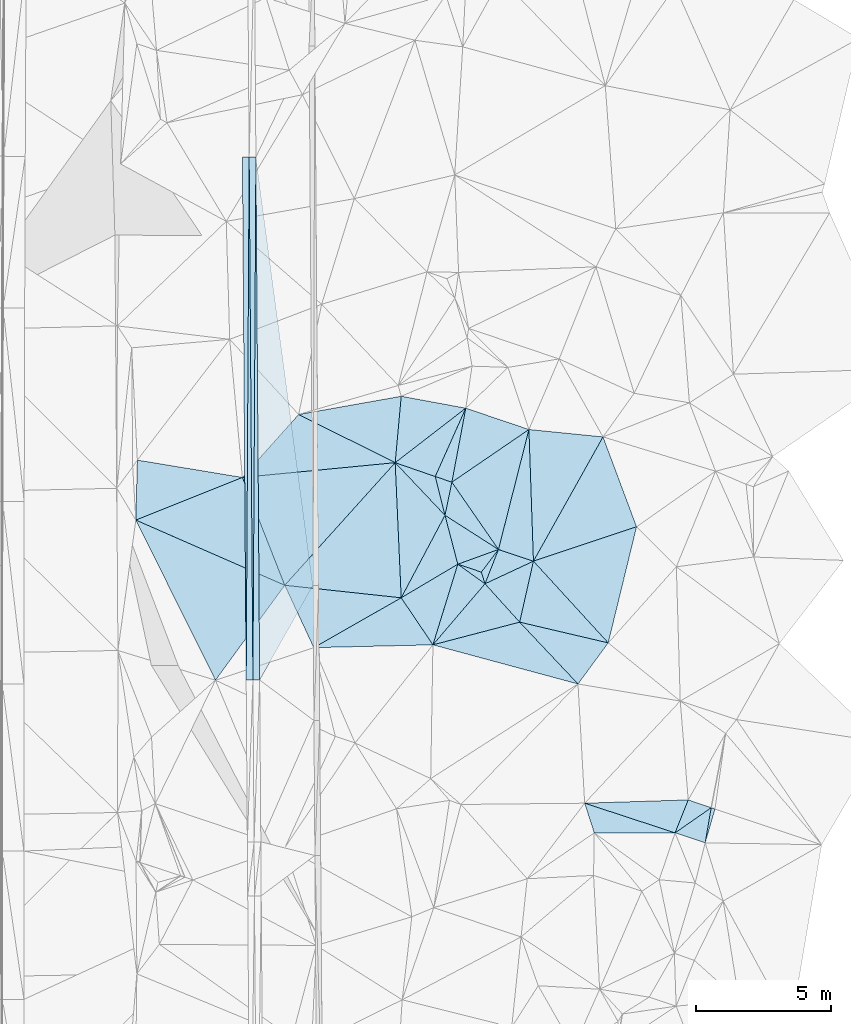
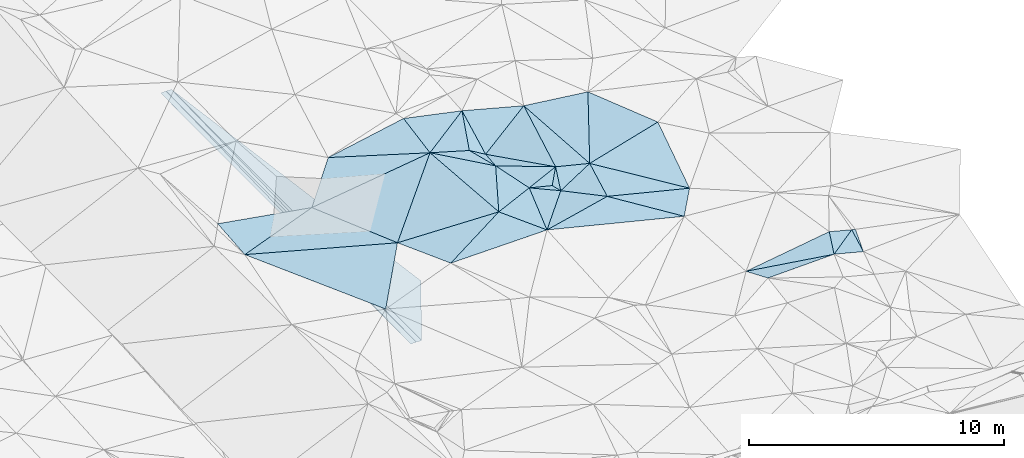
# One storey, part 119 of 275: 45 plates.
"""IFC2X3 building model written with IfcOpenShell, lengths in millimetres."""

from ifc_helpers import new_model, si_unit, frame, origin_with_axes, place, context, subcontext, project, spatial, polyline, outline, extrude, material, type_object, element, save


model = new_model("IFC2X3")

# Units and contexts
model_context = context("Model", 3, precision=1e-05, world=origin_with_axes())
body_context = subcontext(model_context, "Body", "Model", "MODEL_VIEW")
ifc_project = project(units=[si_unit("LENGTHUNIT", "METRE", prefix="MILLI"), si_unit("AREAUNIT", "SQUARE_METRE"), si_unit("VOLUMEUNIT", "CUBIC_METRE"), si_unit("MASSUNIT", "GRAM", prefix="KILO"), si_unit("TIMEUNIT", "SECOND"), si_unit("PLANEANGLEUNIT", "RADIAN"), si_unit("SOLIDANGLEUNIT", "STERADIAN"), si_unit("THERMODYNAMICTEMPERATUREUNIT", "DEGREE_CELSIUS"), si_unit("LUMINOUSINTENSITYUNIT", "LUMEN")], contexts=[model_context])

# Site, building, storey
site_placement = place(None, origin_with_axes())
site = spatial("IfcSite", under=ifc_project, at=site_placement, CompositionType="ELEMENT")
building_placement = place(site_placement, origin_with_axes())
building = spatial("IfcBuilding", under=site, at=building_placement, Name="Undefined", CompositionType="ELEMENT")
storey_placement = place(building_placement, origin_with_axes())
storey = spatial("IfcBuildingStorey", under=building, at=storey_placement, Name="Undefined", CompositionType="ELEMENT", Elevation=0.0)

# Plates
ifc_material = material()
plate_type_1 = type_object("IfcPlateType", PredefinedType="NOTDEFINED")
plate_1_placement = place(storey_placement, frame((-48122.9808228963, 89467.3133438369, 43144.4066906307), z_axis=(-0.0500473094073985, 0.016024451266235, -0.998618287326392), x_axis=(0.00572243998563382, 0.999859466317269, 0.0157575790131864)))
element("IfcPlate", 1, at=plate_1_placement, inside=storey, type_object=plate_type_1, material=ifc_material, Name="00_PR", context=body_context, shape_type="SweptSolid", body=[
    extrude(outline(polyline([(0.0, 0.0), (19378.421875, 1.21683115139604e-07), (3.02767777442932, 250.293533325195), (0.0, 0.0)])), frame((-8.85201319254618e-08, 2.18876761149539e-07, -0.5000001331573), z_axis=(0.0, 0.0, 1.0), x_axis=(1.0, 0.0, 0.0)), (0.0, 0.0, 1.0), 1.0),
])
plate_2_placement = place(storey_placement, frame((-48122.9808228963, 89467.3133438369, 43144.4066906307), z_axis=(-0.0500473094073985, 0.016024451266235, -0.998618287326392), x_axis=(-0.00717867400976242, 0.999839677812784, 0.0164038200029431)))
element("IfcPlate", 2, at=plate_2_placement, inside=storey, type_object=plate_type_1, material=ifc_material, Name="00_PR", context=body_context, shape_type="SweptSolid", body=[
    extrude(outline(polyline([(0.0, 0.0), (19377.009765625, -3.88390617445111e-08), (19376.8046875, 250.311752319336), (0.0, 0.0)])), frame((-8.85201319254618e-08, 2.18876761149539e-07, -0.5000001331573), z_axis=(0.0, 0.0, 1.0), x_axis=(1.0, 0.0, 0.0)), (0.0, 0.0, 1.0), 1.0),
])
for number, where, z_axis, x_axis, name in (
    (3, (-48262.0471143555, 108841.217587926, 43462.2631684603), (0.0198750218653366, 0.016543663038626, -0.999665589444349), (0.0071786740281962, -0.999839677812214, -0.0164038200296701), "00_PR"),
    (4, (-48372.9398667531, 89465.5188689199, 43139.4061675261), (0.0198750218653366, 0.016543663038626, -0.999665589444349), (-0.00717867400976242, 0.999839677812784, 0.0164038200029431), "00_PR"),
):
    element("IfcPlate", number, at=place(storey_placement, frame(where, z_axis=z_axis, x_axis=x_axis)), inside=storey, type_object=plate_type_1, material=ifc_material, Name=name, context=body_context, shape_type="SweptSolid", body=[
        extrude(outline(polyline([(0.0, 0.0), (19377.009765625, -3.88390617445111e-08), (19377.091796875, 250.050430297852), (0.0, 0.0)])), frame((-8.85201319254618e-08, 2.18876761149539e-07, -0.5000001331573), z_axis=(0.0, 0.0, 1.0), x_axis=(1.0, 0.0, 0.0)), (0.0, 0.0, 1.0), 1.0),
    ])
plate_type_2 = type_object("IfcPlateType", PredefinedType="NOTDEFINED")
plate_3_placement = place(storey_placement, frame((-48012.0638828825, 108843.011848514, 43449.763068454), z_axis=(0.000146586582511709, 0.0164052945620828, -0.99986541335457), x_axis=(0.131963060984313, -0.991121552727406, -0.0162424830264985)))
element("IfcPlate", 5, at=plate_3_placement, inside=storey, type_object=plate_type_2, material=ifc_material, Name="00_PR", context=body_context, shape_type="SweptSolid", body=[
    extrude(outline(polyline([(0.0, 0.0), (16020.025390625, -6.14600139670074e-08), (19225.412109375, 2419.09912109375), (0.0, 0.0)])), frame((-8.85201319254618e-08, 2.18876761149539e-07, -0.5000001331573), z_axis=(0.0, 0.0, 1.0), x_axis=(1.0, 0.0, 0.0)), (0.0, 0.0, 1.0), 1.0),
])
plate_type_3 = type_object("IfcPlateType", PredefinedType="NOTDEFINED")
plate_4_placement = place(storey_placement, frame((-37727.8266010062, 93870.9310291532, 45389.5018838814), z_axis=(-0.080682914719458, 0.0314461321567878, -0.996243648935716), x_axis=(0.673052587282011, -0.735499239085719, -0.0777244109486793)))
element("IfcPlate", 6, at=plate_4_placement, inside=storey, type_object=plate_type_3, material=ifc_material, Name="00", context=body_context, shape_type="SweptSolid", body=[
    extrude(outline(polyline([(0.0, 0.0), (4117.11083984375, -2.31375452131033e-09), (1320.63488769531, 1902.84619140625), (0.0, 0.0)])), frame((-8.85201319254618e-08, 2.18876761149539e-07, -0.5000001331573), z_axis=(0.0, 0.0, 1.0), x_axis=(1.0, 0.0, 0.0)), (0.0, 0.0, 1.0), 1.0),
])
plate_type_4 = type_object("IfcPlateType", PredefinedType="NOTDEFINED")
plate_5_placement = place(storey_placement, frame((-40749.8617339183, 96798.9210207401, 45109.5131965546), z_axis=(-0.112277293693529, -0.198650048645683, -0.973617978210101), x_axis=(0.566023629175378, -0.818098694053421, 0.101645354066094)))
element("IfcPlate", 7, at=plate_5_placement, inside=storey, type_object=plate_type_4, material=ifc_material, Name="00", context=body_context, shape_type="SweptSolid", body=[
    extrude(outline(polyline([(0.0, 0.0), (3049.81958007813, -2.15623003896326e-08), (888.675476074219, 928.415771484375), (0.0, 0.0)])), frame((-8.85201319254618e-08, 2.18876761149539e-07, -0.5000001331573), z_axis=(0.0, 0.0, 1.0), x_axis=(1.0, 0.0, 0.0)), (0.0, 0.0, 1.0), 1.0),
])
plate_type_5 = type_object("IfcPlateType", PredefinedType="NOTDEFINED")
plate_6_placement = place(storey_placement, frame((-31363.7656839935, 83432.8939969988, 45269.5046348812), z_axis=(0.00948778259357659, 0.135423983560753, -0.990742310925497), x_axis=(-0.948376948098329, 0.315315594849185, 0.0340182298275974)))
element("IfcPlate", 8, at=plate_6_placement, inside=storey, type_object=plate_type_5, material=ifc_material, Name="00", context=body_context, shape_type="SweptSolid", body=[
    extrude(outline(polyline([(0.0, 0.0), (1175.84008789063, -1.03318598121405e-09), (205.044876098633, 1316.53198242188), (0.0, 0.0)])), frame((-8.85201319254618e-08, 2.18876761149539e-07, -0.5000001331573), z_axis=(0.0, 0.0, 1.0), x_axis=(1.0, 0.0, 0.0)), (0.0, 0.0, 1.0), 1.0),
])
plate_type_6 = type_object("IfcPlateType", PredefinedType="NOTDEFINED")
plate_7_placement = place(storey_placement, frame((-37727.7371115191, 93870.9108578284, 45389.5024445987), z_axis=(0.0984627287842931, -0.00901694546911202, -0.995099887315217), x_axis=(-0.220219844346182, -0.975364271991149, -0.0129521071381955)))
element("IfcPlate", 9, at=plate_7_placement, inside=storey, type_object=plate_type_6, material=ifc_material, Name="00", context=body_context, shape_type="SweptSolid", body=[
    extrude(outline(polyline([(0.0, 0.0), (2316.22534179688, -1.4479155652225e-08), (1214.0009765625, 1573.88098144531), (0.0, 0.0)])), frame((-8.85201319254618e-08, 2.18876761149539e-07, -0.5000001331573), z_axis=(0.0, 0.0, 1.0), x_axis=(1.0, 0.0, 0.0)), (0.0, 0.0, 1.0), 1.0),
])
plate_type_7 = type_object("IfcPlateType", PredefinedType="NOTDEFINED")
plate_8_placement = place(storey_placement, frame((-40749.9827795415, 96799.0940326438, 45109.5382957432), z_axis=(-0.354371805912794, 0.147369052884015, -0.923419181859557), x_axis=(-0.875177603417326, 0.295558053959943, 0.383026890983018)))
element("IfcPlate", 10, at=plate_8_placement, inside=storey, type_object=plate_type_7, material=ifc_material, Name="00", context=body_context, shape_type="SweptSolid", body=[
    extrude(outline(polyline([(0.0, 0.0), (704.911315917969, 1.97906047105789e-09), (451.688018798828, 2764.05102539063), (0.0, 0.0)])), frame((-8.85201319254618e-08, 2.18876761149539e-07, -0.5000001331573), z_axis=(0.0, 0.0, 1.0), x_axis=(1.0, 0.0, 0.0)), (0.0, 0.0, 1.0), 1.0),
])
plate_type_8 = type_object("IfcPlateType", PredefinedType="NOTDEFINED")
plate_9_placement = place(storey_placement, frame((-35149.9221291523, 98476.5256779097, 45119.500676482), z_axis=(-0.0177744832084789, -0.0485965442518217, -0.998660324451438), x_axis=(0.349358261161334, -0.936163116077967, 0.039337329008469)))
element("IfcPlate", 11, at=plate_9_placement, inside=storey, type_object=plate_type_8, material=ifc_material, Name="00", context=body_context, shape_type="SweptSolid", body=[
    extrude(outline(polyline([(0.0, 0.0), (3558.96044921875, -1.43561464938102e-08), (3421.64526367188, 4027.72192382813), (0.0, 0.0)])), frame((-8.85201319254618e-08, 2.18876761149539e-07, -0.5000001331573), z_axis=(0.0, 0.0, 1.0), x_axis=(1.0, 0.0, 0.0)), (0.0, 0.0, 1.0), 1.0),
])
plate_type_9 = type_object("IfcPlateType", PredefinedType="NOTDEFINED")
plate_10_placement = place(storey_placement, frame((-39023.4903981059, 94303.936381236, 45419.5029865571), z_axis=(0.0904023441567215, -0.0609577828379549, -0.994038009777519), x_axis=(-0.56602362917922, 0.818098694050903, -0.101645354064962)))
element("IfcPlate", 12, at=plate_10_placement, inside=storey, type_object=plate_type_9, material=ifc_material, Name="00", context=body_context, shape_type="SweptSolid", body=[
    extrude(outline(polyline([(0.0, 0.0), (3049.81958007813, -2.15623003896326e-08), (3015.71923828125, 3460.5400390625), (0.0, 0.0)])), frame((-8.85201319254618e-08, 2.18876761149539e-07, -0.5000001331573), z_axis=(0.0, 0.0, 1.0), x_axis=(1.0, 0.0, 0.0)), (0.0, 0.0, 1.0), 1.0),
])
plate_type_10 = type_object("IfcPlateType", PredefinedType="NOTDEFINED")
plate_11_placement = place(storey_placement, frame((-37727.8114112109, 93870.9001221443, 45389.5008696403), z_axis=(-0.0503026542644828, -0.0303670749304011, -0.998272249305829), x_axis=(-0.034212409149329, 0.999003407415456, -0.0286653629404365)))
element("IfcPlate", 13, at=plate_11_placement, inside=storey, type_object=plate_type_10, material=ifc_material, Name="00", context=body_context, shape_type="SweptSolid", body=[
    extrude(outline(polyline([(0.0, 0.0), (4883.94287109375, 3.31565388478339e-08), (4520.58935546875, 2737.60375976563), (0.0, 0.0)])), frame((-8.85201319254618e-08, 2.18876761149539e-07, -0.5000001331573), z_axis=(0.0, 0.0, 1.0), x_axis=(1.0, 0.0, 0.0)), (0.0, 0.0, 1.0), 1.0),
])
plate_type_11 = type_object("IfcPlateType", PredefinedType="NOTDEFINED")
plate_12_placement = place(storey_placement, frame((-41005.2536208272, 95570.8929000039, 45389.5523729539), z_axis=(-0.43053371957384, -0.114641399757529, -0.895264243545753), x_axis=(-0.244173331230418, 0.9697081053724, -0.00675090297006514)))
element("IfcPlate", 14, at=plate_12_placement, inside=storey, type_object=plate_type_11, material=ifc_material, Name="00", context=body_context, shape_type="SweptSolid", body=[
    extrude(outline(polyline([(0.0, 0.0), (1481.283203125, 4.82395989820361e-09), (1130.43872070313, 611.398559570313), (0.0, 0.0)])), frame((-8.85201319254618e-08, 2.18876761149539e-07, -0.5000001331573), z_axis=(0.0, 0.0, 1.0), x_axis=(1.0, 0.0, 0.0)), (0.0, 0.0, 1.0), 1.0),
])
plate_type_12 = type_object("IfcPlateType", PredefinedType="NOTDEFINED")
plate_13_placement = place(storey_placement, frame((-39023.5179513791, 94304.0532799282, 45419.5078465396), z_axis=(0.0352952482510373, 0.172836099479648, -0.984318001546024), x_axis=(-0.596145144930375, -0.786865542160084, -0.159541796207323)))
element("IfcPlate", 15, at=plate_13_placement, inside=storey, type_object=plate_type_12, material=ifc_material, Name="00", context=body_context, shape_type="SweptSolid", body=[
    extrude(outline(polyline([(0.0, 0.0), (1065.55151367188, -3.40514816343784e-09), (1352.72668457031, 874.488647460938), (0.0, 0.0)])), frame((-8.85201319254618e-08, 2.18876761149539e-07, -0.5000001331573), z_axis=(0.0, 0.0, 1.0), x_axis=(1.0, 0.0, 0.0)), (0.0, 0.0, 1.0), 1.0),
])
plate_type_13 = type_object("IfcPlateType", PredefinedType="NOTDEFINED")
plate_14_placement = place(storey_placement, frame((-37894.8942615437, 98749.9761838048, 45249.5005020277), z_axis=(-0.0330886544400398, -0.0297986694269383, -0.999008098189265), x_axis=(0.0342124091444801, -0.99900340741576, 0.0286653629356254)))
element("IfcPlate", 16, at=plate_14_placement, inside=storey, type_object=plate_type_13, material=ifc_material, Name="00", context=body_context, shape_type="SweptSolid", body=[
    extrude(outline(polyline([(0.0, 0.0), (4883.94287109375, 3.31565388478339e-08), (4407.8525390625, 1280.91284179688), (0.0, 0.0)])), frame((-8.85201319254618e-08, 2.18876761149539e-07, -0.5000001331573), z_axis=(0.0, 0.0, 1.0), x_axis=(1.0, 0.0, 0.0)), (0.0, 0.0, 1.0), 1.0),
])
plate_type_14 = type_object("IfcPlateType", PredefinedType="NOTDEFINED")
plate_15_placement = place(storey_placement, frame((-39023.5227174912, 94304.0396596911, 45419.5055016167), z_axis=(0.0257626654507343, 0.145599752683723, -0.989008087473157), x_axis=(0.948205169685298, -0.316899041749468, -0.0219534398294409)))
element("IfcPlate", 17, at=plate_15_placement, inside=storey, type_object=plate_type_14, material=ifc_material, Name="00", context=body_context, shape_type="SweptSolid", body=[
    extrude(outline(polyline([(0.0, 0.0), (1366.52844238281, 1.87719706445932e-09), (-66.2262115478516, 1377.72058105469), (0.0, 0.0)])), frame((-8.85201319254618e-08, 2.18876761149539e-07, -0.5000001331573), z_axis=(0.0, 0.0, 1.0), x_axis=(1.0, 0.0, 0.0)), (0.0, 0.0, 1.0), 1.0),
])
plate_type_15 = type_object("IfcPlateType", PredefinedType="NOTDEFINED")
plate_16_placement = place(storey_placement, frame((-39658.7587649784, 93465.5558152671, 45249.5012122396), z_axis=(0.000376762323837831, 0.0694293524422343, -0.99758679976712), x_axis=(0.300210781110649, -0.951578915828308, -0.0661139460019991)))
element("IfcPlate", 18, at=plate_16_placement, inside=storey, type_object=plate_type_15, material=ifc_material, Name="00", context=body_context, shape_type="SweptSolid", body=[
    extrude(outline(polyline([(0.0, 0.0), (453.762054443359, -2.29556462727487e-09), (-541.252868652344, 744.4765625), (0.0, 0.0)])), frame((-8.85201319254618e-08, 2.18876761149539e-07, -0.5000001331573), z_axis=(0.0, 0.0, 1.0), x_axis=(1.0, 0.0, 0.0)), (0.0, 0.0, 1.0), 1.0),
])
plate_type_16 = type_object("IfcPlateType", PredefinedType="NOTDEFINED")
plate_17_placement = place(storey_placement, frame((-40531.3505668799, 93757.6657438974, 45269.5029408336), z_axis=(0.068568606146781, 0.0836988149836219, -0.994129194129931), x_axis=(-0.252211091121483, 0.9655602828409, 0.0638976190128594)))
element("IfcPlate", 19, at=plate_17_placement, inside=storey, type_object=plate_type_16, material=ifc_material, Name="00", context=body_context, shape_type="SweptSolid", body=[
    extrude(outline(polyline([(0.0, 0.0), (1878.00427246094, 1.86810211744159e-09), (156.815399169922, 1603.12475585938), (0.0, 0.0)])), frame((-8.85201319254618e-08, 2.18876761149539e-07, -0.5000001331573), z_axis=(0.0, 0.0, 1.0), x_axis=(1.0, 0.0, 0.0)), (0.0, 0.0, 1.0), 1.0),
])
plate_type_17 = type_object("IfcPlateType", PredefinedType="NOTDEFINED")
plate_18_placement = place(storey_placement, frame((-34956.7807458992, 90842.812037416, 45069.5015190974), z_axis=(-0.052901474210557, 0.0569460795665654, -0.996974712842983), x_axis=(-0.673052587295684, 0.735499239074036, 0.0777244109408357)))
element("IfcPlate", 20, at=plate_18_placement, inside=storey, type_object=plate_type_17, material=ifc_material, Name="00", context=body_context, shape_type="SweptSolid", body=[
    extrude(outline(polyline([(0.0, 0.0), (4117.11083984375, -2.31375452131033e-09), (2472.04907226563, 3679.01782226563), (0.0, 0.0)])), frame((-8.85201319254618e-08, 2.18876761149539e-07, -0.5000001331573), z_axis=(0.0, 0.0, 1.0), x_axis=(1.0, 0.0, 0.0)), (0.0, 0.0, 1.0), 1.0),
])
plate_type_18 = type_object("IfcPlateType", PredefinedType="NOTDEFINED")
plate_19_placement = place(storey_placement, frame((-39522.4734234203, 93033.7843047484, 45219.5066777543), z_axis=(0.122540852766194, 0.107211064681001, -0.986655728718635), x_axis=(-0.300210781116809, 0.951578915826714, 0.0661139459969808)))
element("IfcPlate", 21, at=plate_19_placement, inside=storey, type_object=plate_type_18, material=ifc_material, Name="00", context=body_context, shape_type="SweptSolid", body=[
    extrude(outline(polyline([(0.0, 0.0), (453.762054443359, -2.29556462727487e-09), (1072.14782714844, 867.755187988281), (0.0, 0.0)])), frame((-8.85201319254618e-08, 2.18876761149539e-07, -0.5000001331573), z_axis=(0.0, 0.0, 1.0), x_axis=(1.0, 0.0, 0.0)), (0.0, 0.0, 1.0), 1.0),
])
plate_type_19 = type_object("IfcPlateType", PredefinedType="NOTDEFINED")
plate_20_placement = place(storey_placement, frame((-39522.5280701252, 93033.6876433415, 45219.5019067768), z_axis=(0.0132467953505022, -0.0861123031991422, -0.996197366815774), x_axis=(0.668591136258281, -0.740052104085696, 0.0728613460978829)))
element("IfcPlate", 22, at=plate_20_placement, inside=storey, type_object=plate_type_19, material=ifc_material, Name="00", context=body_context, shape_type="SweptSolid", body=[
    extrude(outline(polyline([(0.0, 0.0), (1921.45776367188, 8.75661498866975e-09), (397.406585693359, 2952.53588867188), (0.0, 0.0)])), frame((-8.85201319254618e-08, 2.18876761149539e-07, -0.5000001331573), z_axis=(0.0, 0.0, 1.0), x_axis=(1.0, 0.0, 0.0)), (0.0, 0.0, 1.0), 1.0),
])
plate_type_20 = type_object("IfcPlateType", PredefinedType="NOTDEFINED")
plate_21_placement = place(storey_placement, frame((-34956.7898384862, 90842.8195021556, 45069.5025673802), z_axis=(-0.0710871790636121, 0.0718748448805464, -0.994877188222836), x_axis=(-0.592359464910988, -0.805517506131453, -0.0158685741682458)))
element("IfcPlate", 23, at=plate_21_placement, inside=storey, type_object=plate_type_20, material=ifc_material, Name="00", context=body_context, shape_type="SweptSolid", body=[
    extrude(outline(polyline([(0.0, 0.0), (1890.52905273438, -3.39059624820948e-09), (1319.57775878906, 3114.45263671875), (0.0, 0.0)])), frame((-8.85201319254618e-08, 2.18876761149539e-07, -0.5000001331573), z_axis=(0.0, 0.0, 1.0), x_axis=(1.0, 0.0, 0.0)), (0.0, 0.0, 1.0), 1.0),
])
plate_type_21 = type_object("IfcPlateType", PredefinedType="NOTDEFINED")
plate_22_placement = place(storey_placement, frame((-38237.8833428072, 91611.8039661408, 45359.5030677998), z_axis=(-0.0365772784975865, 0.104278532994865, -0.993875289085179), x_axis=(0.682563524106156, -0.723804798867315, -0.101062597910555)))
element("IfcPlate", 24, at=plate_22_placement, inside=storey, type_object=plate_type_21, material=ifc_material, Name="00", context=body_context, shape_type="SweptSolid", body=[
    extrude(outline(polyline([(0.0, 0.0), (3166.3544921875, -1.78770278580487e-08), (-1587.85131835938, 2918.72021484375), (0.0, 0.0)])), frame((-8.85201319254618e-08, 2.18876761149539e-07, -0.5000001331573), z_axis=(0.0, 0.0, 1.0), x_axis=(1.0, 0.0, 0.0)), (0.0, 0.0, 1.0), 1.0),
])
plate_type_22 = type_object("IfcPlateType", PredefinedType="NOTDEFINED")
plate_23_placement = place(storey_placement, frame((-31991.1700905661, 85025.1753849519, 45479.5045187698), z_axis=(0.0107707580183382, 0.133614066467999, -0.99097490988097), x_axis=(0.945584546155765, -0.323661599866354, -0.033362176837685)))
element("IfcPlate", 25, at=plate_23_placement, inside=storey, type_object=plate_type_22, material=ifc_material, Name="00", context=body_context, shape_type="SweptSolid", body=[
    extrude(outline(polyline([(0.0, 0.0), (899.221862792969, -1.73167791217566e-09), (-60.1631278991699, 1324.86999511719), (0.0, 0.0)])), frame((-8.85201319254618e-08, 2.18876761149539e-07, -0.5000001331573), z_axis=(0.0, 0.0, 1.0), x_axis=(1.0, 0.0, 0.0)), (0.0, 0.0, 1.0), 1.0),
])
plate_type_23 = type_object("IfcPlateType", PredefinedType="NOTDEFINED")
plate_24_placement = place(storey_placement, frame((-31140.8635650484, 84734.1298017342, 45449.5046959273), z_axis=(0.0431835440785026, 0.129635546440962, -0.990620919736593), x_axis=(0.948745425085232, -0.316041323848391, 1.70029327735896e-10)))
element("IfcPlate", 26, at=plate_24_placement, inside=storey, type_object=plate_type_23, material=ifc_material, Name="00", context=body_context, shape_type="SweptSolid", body=[
    extrude(outline(polyline([(0.0, 0.0), (148.660690307617, 2.47382558882236e-10), (199.783813476563, 1317.34069824219), (0.0, 0.0)])), frame((-8.85201319254618e-08, 2.18876761149539e-07, -0.5000001331573), z_axis=(0.0, 0.0, 1.0), x_axis=(1.0, 0.0, 0.0)), (0.0, 0.0, 1.0), 1.0),
])
plate_type_24 = type_object("IfcPlateType", PredefinedType="NOTDEFINED")
plate_25_placement = place(storey_placement, frame((-32478.8497038633, 83803.631694375, 45309.5056818039), z_axis=(0.120786747267147, 0.0893625512525177, -0.988648014269115), x_axis=(-0.946531691025131, 0.310496740842927, -0.087575863176026)))
element("IfcPlate", 27, at=plate_25_placement, inside=storey, type_object=plate_type_24, material=ifc_material, Name="00", context=body_context, shape_type="SweptSolid", body=[
    extrude(outline(polyline([(0.0, 0.0), (3539.7880859375, 3.05590219795704e-10), (-97.2657089233398, 1322.66369628906), (0.0, 0.0)])), frame((-8.85201319254618e-08, 2.18876761149539e-07, -0.5000001331573), z_axis=(0.0, 0.0, 1.0), x_axis=(1.0, 0.0, 0.0)), (0.0, 0.0, 1.0), 1.0),
])
plate_type_25 = type_object("IfcPlateType", PredefinedType="NOTDEFINED")
plate_26_placement = place(storey_placement, frame((-35474.1746749848, 83802.2668341385, 45219.5090274375), z_axis=(0.0295815977631143, -0.186783572318515, -0.98195561314436), x_axis=(-0.301823274079135, 0.934860647808372, -0.186917843994259)))
element("IfcPlate", 28, at=plate_26_placement, inside=storey, type_object=plate_type_25, material=ifc_material, Name="00", context=body_context, shape_type="SweptSolid", body=[
    extrude(outline(polyline([(0.0, 0.0), (1176.98767089844, 2.25554686039686e-10), (-919.720764160156, 2852.00170898438), (0.0, 0.0)])), frame((-8.85201319254618e-08, 2.18876761149539e-07, -0.5000001331573), z_axis=(0.0, 0.0, 1.0), x_axis=(1.0, 0.0, 0.0)), (0.0, 0.0, 1.0), 1.0),
])
plate_type_26 = type_object("IfcPlateType", PredefinedType="NOTDEFINED")
plate_27_placement = place(storey_placement, frame((-42851.2121888948, 97520.9840433633, 45479.5016289314), z_axis=(-0.0761850849984336, -0.0261226432295661, -0.996751443607925), x_axis=(0.943118583344109, -0.326329354948163, -0.0635333758753378)))
element("IfcPlate", 29, at=plate_27_placement, inside=storey, type_object=plate_type_26, material=ifc_material, Name="00", context=body_context, shape_type="SweptSolid", body=[
    extrude(outline(polyline([(0.0, 0.0), (1573.97583007813, -7.74161890149117e-09), (2383.20043945313, 1240.70764160156), (0.0, 0.0)])), frame((-8.85201319254618e-08, 2.18876761149539e-07, -0.5000001331573), z_axis=(0.0, 0.0, 1.0), x_axis=(1.0, 0.0, 0.0)), (0.0, 0.0, 1.0), 1.0),
])
plate_type_27 = type_object("IfcPlateType", PredefinedType="NOTDEFINED")
plate_28_placement = place(storey_placement, frame((-41005.0781858345, 95570.9355119672, 45389.5018110205), z_axis=(-0.0796588593439748, -0.0294281003286373, -0.996387702171732), x_axis=(-0.467842638580197, -0.881532067540762, 0.0634387848530271)))
element("IfcPlate", 30, at=plate_28_placement, inside=storey, type_object=plate_type_27, material=ifc_material, Name="00", context=body_context, shape_type="SweptSolid", body=[
    extrude(outline(polyline([(0.0, 0.0), (3467.90991210938, -4.88944351673126e-09), (-849.618347167969, 2548.95043945313), (0.0, 0.0)])), frame((-8.85201319254618e-08, 2.18876761149539e-07, -0.5000001331573), z_axis=(0.0, 0.0, 1.0), x_axis=(1.0, 0.0, 0.0)), (0.0, 0.0, 1.0), 1.0),
])
plate_type_28 = type_object("IfcPlateType", PredefinedType="NOTDEFINED")
plate_29_placement = place(storey_placement, frame((-42627.01287194, 99981.7737473387, 45549.5003892876), z_axis=(0.0296012627651281, 0.0257282418469203, -0.999230615430781), x_axis=(-0.090676226858363, -0.995477736323768, -0.0283178100572396)))
element("IfcPlate", 31, at=plate_29_placement, inside=storey, type_object=plate_type_28, material=ifc_material, Name="00", context=body_context, shape_type="SweptSolid", body=[
    extrude(outline(polyline([(0.0, 0.0), (2471.94262695313, 1.33150024339557e-09), (1020.20977783203, 3726.25439453125), (0.0, 0.0)])), frame((-8.85201319254618e-08, 2.18876761149539e-07, -0.5000001331573), z_axis=(0.0, 0.0, 1.0), x_axis=(1.0, 0.0, 0.0)), (0.0, 0.0, 1.0), 1.0),
])
plate_type_29 = type_object("IfcPlateType", PredefinedType="NOTDEFINED")
plate_30_placement = place(storey_placement, frame((-42627.4468903394, 92513.8646012652, 45609.5009069535), z_axis=(0.0552923960677207, -0.0234458999911983, -0.99819489114636), x_axis=(-0.99261817647025, 0.106788816882269, -0.0574917761924283)))
element("IfcPlate", 32, at=plate_30_placement, inside=storey, type_object=plate_type_29, material=ifc_material, Name="00", context=body_context, shape_type="SweptSolid", body=[
    extrude(outline(polyline([(0.0, 0.0), (4348.4482421875, -1.13795977085829e-08), (764.226684570313, 4955.21533203125), (0.0, 0.0)])), frame((-8.85201319254618e-08, 2.18876761149539e-07, -0.5000001331573), z_axis=(0.0, 0.0, 1.0), x_axis=(1.0, 0.0, 0.0)), (0.0, 0.0, 1.0), 1.0),
])
plate_type_30 = type_object("IfcPlateType", PredefinedType="NOTDEFINED")
plate_31_placement = place(storey_placement, frame((-41452.1621198695, 90770.2525597651, 45389.5070573732), z_axis=(-0.166950637117393, 0.0118509077715498, -0.985894031197617), x_axis=(-0.555930743174236, 0.824690094922855, 0.104054101936806)))
element("IfcPlate", 33, at=plate_31_placement, inside=storey, type_object=plate_type_30, material=ifc_material, Name="00", context=body_context, shape_type="SweptSolid", body=[
    extrude(outline(polyline([(0.0, 0.0), (2114.28466796875, -1.00590114016086e-08), (1939.33190917969, 2454.68774414063), (0.0, 0.0)])), frame((-8.85201319254618e-08, 2.18876761149539e-07, -0.5000001331573), z_axis=(0.0, 0.0, 1.0), x_axis=(1.0, 0.0, 0.0)), (0.0, 0.0, 1.0), 1.0),
])
plate_type_31 = type_object("IfcPlateType", PredefinedType="NOTDEFINED")
plate_32_placement = place(storey_placement, frame((-41452.1106669219, 90770.236464434, 45389.5011345744), z_axis=(-0.0640442608345224, -0.0203401217764348, -0.997739751688926), x_axis=(0.294307624891867, 0.954940630203968, -0.038359023920809)))
element("IfcPlate", 34, at=plate_32_placement, inside=storey, type_object=plate_type_31, material=ifc_material, Name="00", context=body_context, shape_type="SweptSolid", body=[
    extrude(outline(polyline([(0.0, 0.0), (3128.33813476563, 1.29075488075614e-08), (2735.8935546875, 1179.10437011719), (0.0, 0.0)])), frame((-8.85201319254618e-08, 2.18876761149539e-07, -0.5000001331573), z_axis=(0.0, 0.0, 1.0), x_axis=(1.0, 0.0, 0.0)), (0.0, 0.0, 1.0), 1.0),
])
plate_type_32 = type_object("IfcPlateType", PredefinedType="NOTDEFINED")
plate_33_placement = place(storey_placement, frame((-42851.2125771596, 97521.014821885, 45479.5017833743), z_axis=(-0.0767979114420325, 0.0353399989075214, -0.996420175064394), x_axis=(0.0906762263963344, 0.995477736364248, 0.0283178101136576)))
element("IfcPlate", 35, at=plate_33_placement, inside=storey, type_object=plate_type_32, material=ifc_material, Name="00", context=body_context, shape_type="SweptSolid", body=[
    extrude(outline(polyline([(0.0, 0.0), (2471.94262695313, 1.33150024339557e-09), (2244.91455078125, 2430.11499023438), (0.0, 0.0)])), frame((-8.85201319254618e-08, 2.18876761149539e-07, -0.5000001331573), z_axis=(0.0, 0.0, 1.0), x_axis=(1.0, 0.0, 0.0)), (0.0, 0.0, 1.0), 1.0),
])
plate_type_33 = type_object("IfcPlateType", PredefinedType="NOTDEFINED")
plate_34_placement = place(storey_placement, frame((-48513.8493507925, 96974.7137980685, 45169.5010837098), z_axis=(-0.042963854696274, 0.0504706548492764, -0.997800992276878), x_axis=(-0.928092293932896, -0.371748583665732, 0.0211585558320487)))
element("IfcPlate", 36, at=plate_34_placement, inside=storey, type_object=plate_type_33, material=ifc_material, Name="00", context=body_context, shape_type="SweptSolid", body=[
    extrude(outline(polyline([(0.0, 0.0), (4253.5986328125, -2.19733919948339e-09), (3377.61083984375, 2046.30041503906), (0.0, 0.0)])), frame((-8.85201319254618e-08, 2.18876761149539e-07, -0.5000001331573), z_axis=(0.0, 0.0, 1.0), x_axis=(1.0, 0.0, 0.0)), (0.0, 0.0, 1.0), 1.0),
])
plate_type_34 = type_object("IfcPlateType", PredefinedType="NOTDEFINED")
plate_35_placement = place(storey_placement, frame((-46943.8247498513, 92978.2176211655, 45359.5005816667), z_axis=(-0.00324041003199345, -0.0487584336223146, -0.998805343845097), x_axis=(-0.915959907521425, 0.400926275532891, -0.0166002831502146)))
element("IfcPlate", 37, at=plate_35_placement, inside=storey, type_object=plate_type_34, material=ifc_material, Name="00", context=body_context, shape_type="SweptSolid", body=[
    extrude(outline(polyline([(0.0, 0.0), (6023.99365234375, -7.50151230022311e-09), (3043.49584960938, 3034.75415039063), (0.0, 0.0)])), frame((-8.85201319254618e-08, 2.18876761149539e-07, -0.5000001331573), z_axis=(0.0, 0.0, 1.0), x_axis=(1.0, 0.0, 0.0)), (0.0, 0.0, 1.0), 1.0),
])
plate_type_35 = type_object("IfcPlateType", PredefinedType="NOTDEFINED")
plate_36_placement = place(storey_placement, frame((-42851.1456517232, 97520.9846338168, 45479.5009648076), z_axis=(0.0570536863144943, -0.0250363159752382, -0.998057142532588), x_axis=(-0.669212507576228, -0.742811955482289, -0.0196218881893445)))
element("IfcPlate", 38, at=plate_36_placement, inside=storey, type_object=plate_type_35, material=ifc_material, Name="00", context=body_context, shape_type="SweptSolid", body=[
    extrude(outline(polyline([(0.0, 0.0), (6115.619140625, 1.5905243344605e-08), (4201.40625, 3848.16674804688), (0.0, 0.0)])), frame((-8.85201319254618e-08, 2.18876761149539e-07, -0.5000001331573), z_axis=(0.0, 0.0, 1.0), x_axis=(1.0, 0.0, 0.0)), (0.0, 0.0, 1.0), 1.0),
])
plate_type_36 = type_object("IfcPlateType", PredefinedType="NOTDEFINED")
plate_37_placement = place(storey_placement, frame((-52461.5463823729, 95393.4294041497, 45259.5002740085), z_axis=(0.026923822074611, 0.0201289895828783, -0.999434806069544), x_axis=(0.915959907518569, -0.400926275540132, 0.0166002831329282)))
element("IfcPlate", 39, at=plate_37_placement, inside=storey, type_object=plate_type_36, material=ifc_material, Name="00", context=body_context, shape_type="SweptSolid", body=[
    extrude(outline(polyline([(0.0, 0.0), (6023.99365234375, -7.50151230022311e-09), (5081.3134765625, 4253.96923828125), (0.0, 0.0)])), frame((-8.85201319254618e-08, 2.18876761149539e-07, -0.5000001331573), z_axis=(0.0, 0.0, 1.0), x_axis=(1.0, 0.0, 0.0)), (0.0, 0.0, 1.0), 1.0),
])
plate_type_37 = type_object("IfcPlateType", PredefinedType="NOTDEFINED")
plate_38_placement = place(storey_placement, frame((-48513.8036584802, 96974.7203222127, 45169.5015910596), z_axis=(0.0484389360824022, 0.0635463247220457, -0.996802655536955), x_axis=(0.664375248654057, 0.743141824581249, 0.0796602632051412)))
element("IfcPlate", 40, at=plate_38_placement, inside=storey, type_object=plate_type_37, material=ifc_material, Name="00", context=body_context, shape_type="SweptSolid", body=[
    extrude(outline(polyline([(0.0, 0.0), (3138.32763671875, -2.19151843339205e-08), (4192.806640625, 3857.53466796875), (0.0, 0.0)])), frame((-8.85201319254618e-08, 2.18876761149539e-07, -0.5000001331573), z_axis=(0.0, 0.0, 1.0), x_axis=(1.0, 0.0, 0.0)), (0.0, 0.0, 1.0), 1.0),
])
plate_type_38 = type_object("IfcPlateType", PredefinedType="NOTDEFINED")
plate_39_placement = place(storey_placement, frame((-45866.9873998871, 90666.2137201857, 45409.5008543446), z_axis=(0.0584242878644787, 0.0056218334853098, -0.998276012721828), x_axis=(-0.422114811710997, 0.906330466012043, -0.0196003089920311)))
element("IfcPlate", 41, at=plate_39_placement, inside=storey, type_object=plate_type_38, material=ifc_material, Name="00", context=body_context, shape_type="SweptSolid", body=[
    extrude(outline(polyline([(0.0, 0.0), (2550.98022460938, 1.01476871350314e-08), (303.216766357422, 3722.43994140625), (0.0, 0.0)])), frame((-8.85201319254618e-08, 2.18876761149539e-07, -0.5000001331573), z_axis=(0.0, 0.0, 1.0), x_axis=(1.0, 0.0, 0.0)), (0.0, 0.0, 1.0), 1.0),
])
plate_type_39 = type_object("IfcPlateType", PredefinedType="NOTDEFINED")
plate_40_placement = place(storey_placement, frame((-41005.1243404534, 95570.9604255308, 45389.5075328779), z_axis=(-0.171807230059353, 0.0203016241260901, -0.984921377449579), x_axis=(0.252211091590199, -0.965560282716234, -0.0638976190466186)))
element("IfcPlate", 42, at=plate_40_placement, inside=storey, type_object=plate_type_39, material=ifc_material, Name="00", context=body_context, shape_type="SweptSolid", body=[
    extrude(outline(polyline([(0.0, 0.0), (1878.00427246094, 1.86810211744159e-09), (2528.53515625, 2373.375), (0.0, 0.0)])), frame((-8.85201319254618e-08, 2.18876761149539e-07, -0.5000001331573), z_axis=(0.0, 0.0, 1.0), x_axis=(1.0, 0.0, 0.0)), (0.0, 0.0, 1.0), 1.0),
])
plate_type_40 = type_object("IfcPlateType", PredefinedType="NOTDEFINED")
plate_41_placement = place(storey_placement, frame((-42627.4782817782, 92513.9365280556, 45609.5036383859), z_axis=(-0.00733211545344398, 0.120311027732137, -0.992709170245251), x_axis=(0.555930743557285, -0.824690094658229, -0.104054101987601)))
element("IfcPlate", 43, at=plate_41_placement, inside=storey, type_object=plate_type_40, material=ifc_material, Name="00", context=body_context, shape_type="SweptSolid", body=[
    extrude(outline(polyline([(0.0, 0.0), (2114.28466796875, -1.00590114016086e-08), (-256.398773193359, 3725.95751953125), (0.0, 0.0)])), frame((-8.85201319254618e-08, 2.18876761149539e-07, -0.5000001331573), z_axis=(0.0, 0.0, 1.0), x_axis=(1.0, 0.0, 0.0)), (0.0, 0.0, 1.0), 1.0),
])
plate_type_41 = type_object("IfcPlateType", PredefinedType="NOTDEFINED")
plate_42_placement = place(storey_placement, frame((-40234.7475213258, 99541.4876444409, 45349.5010116557), z_axis=(-0.061768719883716, 0.015778252387624, -0.9979657669457), x_axis=(-0.407840118668396, -0.912989384769835, 0.0108083718545393)))
element("IfcPlate", 44, at=plate_42_placement, inside=storey, type_object=plate_type_41, material=ifc_material, Name="00", context=body_context, shape_type="SweptSolid", body=[
    extrude(outline(polyline([(0.0, 0.0), (2775.6259765625, 1.70985003933311e-08), (2913.1806640625, 1567.95373535156), (0.0, 0.0)])), frame((-8.85201319254618e-08, 2.18876761149539e-07, -0.5000001331573), z_axis=(0.0, 0.0, 1.0), x_axis=(1.0, 0.0, 0.0)), (0.0, 0.0, 1.0), 1.0),
])
plate_type_42 = type_object("IfcPlateType", PredefinedType="NOTDEFINED")
plate_43_placement = place(storey_placement, frame((-40234.7228252852, 99541.5244967197, 45349.5020384059), z_axis=(-0.0123002466253567, 0.0894653476486725, -0.995913979971693), x_axis=(0.946496785323243, -0.320167959511473, -0.0404513667881119)))
element("IfcPlate", 45, at=plate_43_placement, inside=storey, type_object=plate_type_42, material=ifc_material, Name="00", context=body_context, shape_type="SweptSolid", body=[
    extrude(outline(polyline([(0.0, 0.0), (2472.10424804688, 4.43833414465189e-09), (400.225830078125, 2771.97021484375), (0.0, 0.0)])), frame((-8.85201319254618e-08, 2.18876761149539e-07, -0.5000001331573), z_axis=(0.0, 0.0, 1.0), x_axis=(1.0, 0.0, 0.0)), (0.0, 0.0, 1.0), 1.0),
])

save(model, "model.ifc")
